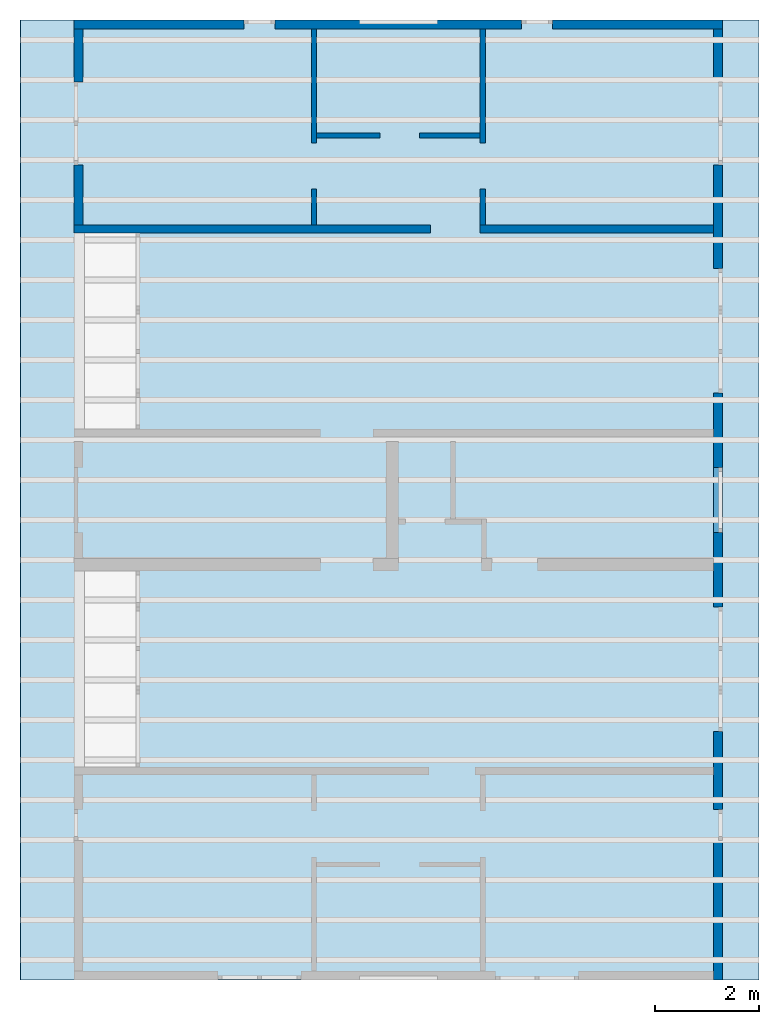
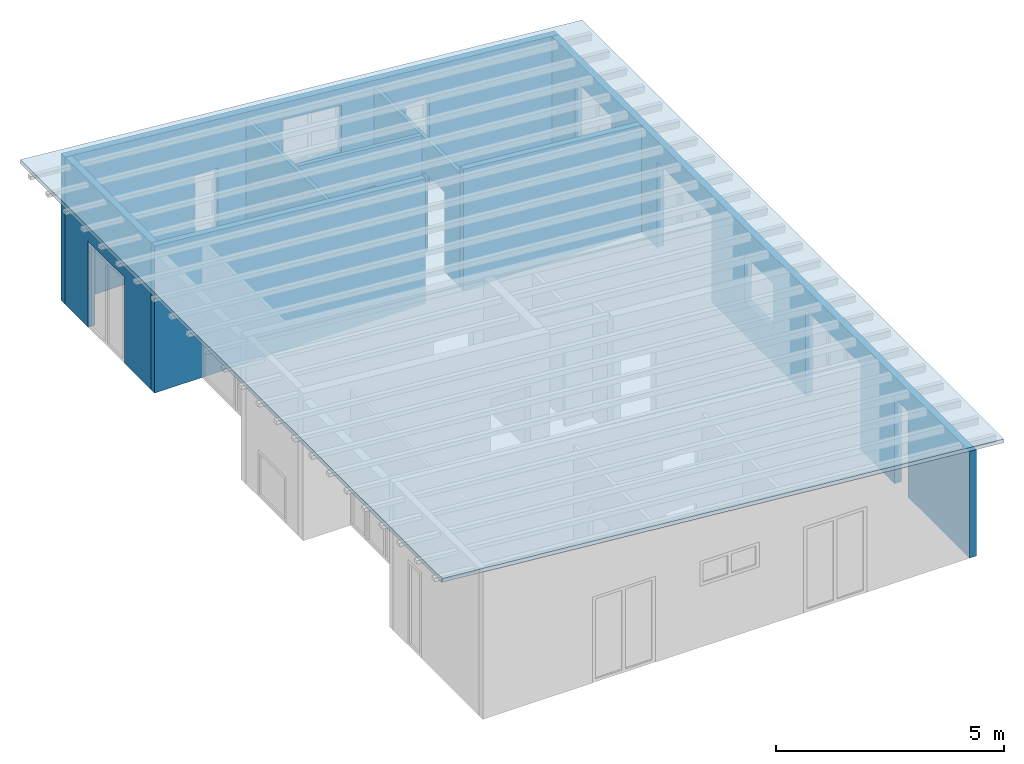
# One storey, part 2 of 13: 8 walls, 1 roof, 14 openings.
"""IFC2X3 building model written with IfcOpenShell, lengths in millimetres."""

from ifc_helpers import new_model, entity, si_unit, converted_unit, frame, frame_2d, origin, origin_with_axes, place, context, project, spatial, polyline, rectangle, outline, extrude, clip, halfspace, faceted_brep, material, layer, layer_set, layer_usage, element, save


model = new_model("IFC2X3")

# Units and contexts
model_context = context("Model", 3, precision=1e-05, world=origin())
plan_context = context("Plan", 3, precision=1e-05, world=origin())
ifc_project = project(units=[si_unit("LENGTHUNIT", "METRE", prefix="MILLI"), converted_unit("PLANEANGLEUNIT", "DEGREE", entity("IfcPlaneAngleMeasure", 0.0174532925199433), si_unit("PLANEANGLEUNIT", "RADIAN"), dimensions=[0, 0, 0, 0, 0, 0, 0]), si_unit("AREAUNIT", "SQUARE_METRE"), si_unit("VOLUMEUNIT", "CUBIC_METRE")], contexts=[model_context, plan_context])

# Building, storey
building_placement = place(None, origin())
building = spatial("IfcBuilding", under=ifc_project, at=building_placement, CompositionType="ELEMENT")
storey_placement = place(building_placement, frame((0.0, 0.0, 4770.0), z_axis=(0.0, 0.0, 1.0), x_axis=(1.0, 0.0, 0.0)))
storey = spatial("IfcBuildingStorey", under=building, at=storey_placement, Name="Geschoss", CompositionType="ELEMENT", Elevation=4770.0)

# Walls
ifc_material_1 = material()
ifc_layer_1 = layer(ifc_material_1, 150.0)
ifc_layer_set_1 = layer_set([ifc_layer_1])
ifc_layer_usage_1 = layer_usage(ifc_layer_set_1, "AXIS2", "POSITIVE", 0.0)
wall_1_placement = place(storey_placement, frame((21188.3517822139, 5708.4375, 0.0), z_axis=(0.0, 0.0, 1.0), x_axis=(1.0, 0.0, 0.0)))
element("IfcWallStandardCase", 1, at=wall_1_placement, inside=storey, material=ifc_layer_usage_1, context=model_context, shape_type="Clipping", body=[
    clip(extrude(rectangle(XDim=6865.03345220687, YDim=150.0, at=frame_2d((3432.51672610344, 75.0), x_axis=(1.0, 0.0))), origin_with_axes(), (0.0, 0.0, 1.0), 3940.60829407405), halfspace(frame((6865.03345220687, 150.0, 3339.99569227971), z_axis=(-0.0871557427476578, 1.12621278238497e-16, -0.996194698091746), x_axis=(1.0, 0.0, 0.0)), True)),
])
ifc_material_2 = material()
ifc_layer_2 = layer(ifc_material_2, 150.0)
ifc_layer_set_2 = layer_set([ifc_layer_2])
ifc_layer_usage_2 = layer_usage(ifc_layer_set_2, "AXIS2", "POSITIVE", 0.0)
wall_2_placement = place(storey_placement, frame((29013.3517822549, 5708.4375, 0.0), z_axis=(0.0, 0.0, 1.0), x_axis=(1.0, 0.0, 0.0)))
element("IfcWallStandardCase", 2, at=wall_2_placement, inside=storey, material=ifc_layer_usage_2, context=model_context, shape_type="Clipping", body=[
    clip(extrude(rectangle(XDim=4499.99999991432, YDim=150.0, at=frame_2d((2249.99999995716, 75.0), x_axis=(1.0, 0.0))), origin_with_axes(), (0.0, 0.0, 1.0), 3256.00950198011), halfspace(frame((0.0, 0.0, 3256.00950198011), z_axis=(-0.0871557427476577, 8.59054269502555e-17, -0.996194698091746), x_axis=(1.0, 0.0, 0.0)), True)),
])

# Wall, opening
ifc_material_3 = material(Name="GD")
ifc_layer_3 = layer(ifc_material_3, 100.0)
ifc_layer_set_3 = layer_set([ifc_layer_3])
ifc_layer_usage_3 = layer_usage(ifc_layer_set_3, "AXIS2", "POSITIVE", 0.0)
wall_3_placement = place(storey_placement, frame((25763.3517822549, 9633.4375, 0.0), z_axis=(0.0, 0.0, 1.0), x_axis=(0.0, -1.0, 0.0)))
wall_3 = element("IfcWallStandardCase", 3, at=wall_3_placement, inside=storey, material=ifc_layer_usage_3, context=model_context, shape_type="Clipping", body=[
    clip(extrude(rectangle(XDim=3775.0, YDim=100.0, at=frame_2d((1887.5, 50.0), x_axis=(1.0, 0.0))), origin_with_axes(), (0.0, 0.0, 1.0), 3340.34765843936), halfspace(frame((0.0, 0.0, 3340.34765843936), z_axis=(0.0, -0.0871557427476622, -0.996194698091745), x_axis=(1.0, 0.0, 0.0)), True)),
])
opening_1_placement = place(wall_3_placement, frame((2199.99999999615, 0.0, 0.0), z_axis=(0.0, 1.0, 0.0), x_axis=(0.0, 0.0, 1.0)))
element("IfcOpeningElement", 4, at=opening_1_placement, cuts=wall_3, ObjectType="Opening", context=model_context, shape_type="SweptSolid", body=[
    extrude(rectangle(XDim=2130.0, YDim=885.000000000514, at=frame_2d((1065.0, 442.500000000257), x_axis=(1.0, 0.0))), origin_with_axes(), (0.0, 0.0, 1.0), 100.0),
])

ifc_material_4 = material(Name="GD")
ifc_layer_4 = layer(ifc_material_4, 99.9999999180436)
ifc_layer_set_4 = layer_set([ifc_layer_4])
ifc_layer_usage_4 = layer_usage(ifc_layer_set_4, "AXIS2", "POSITIVE", 0.0)
wall_4_placement = place(storey_placement, frame((29113.3517821729, 5858.4375, 0.0), z_axis=(0.0, 0.0, 1.0), x_axis=(0.0, 1.0, 0.0)))
wall_4 = element("IfcWallStandardCase", 5, at=wall_4_placement, inside=storey, material=ifc_layer_usage_4, context=model_context, shape_type="Clipping", body=[
    clip(extrude(rectangle(XDim=3775.0, YDim=99.9999999180436, at=frame_2d((1887.5, 49.9999999590218), x_axis=(1.0, 0.0))), origin_with_axes(), (0.0, 0.0, 1.0), 3056.00950198011), halfspace(frame((0.0, 0.0, 3047.26063563469), z_axis=(0.0, 0.0871557427476603, -0.996194698091745), x_axis=(1.0, 0.0, 0.0)), True)),
])
opening_2_placement = place(wall_4_placement, frame((690.000000003335, 0.0, 0.0), z_axis=(0.0, 1.0, 0.0), x_axis=(0.0, 0.0, 1.0)))
element("IfcOpeningElement", 6, at=opening_2_placement, cuts=wall_4, ObjectType="Opening", context=model_context, shape_type="SweptSolid", body=[
    extrude(rectangle(XDim=2130.0, YDim=885.000000000514, at=frame_2d((1065.0, 442.500000000257), x_axis=(1.0, 0.0))), origin_with_axes(), (0.0, 0.0, 1.0), 99.9999999180436),
])

ifc_material_5 = material()
ifc_layer_5 = layer(ifc_material_5, 175.0)
ifc_layer_set_5 = layer_set([ifc_layer_5])
ifc_layer_usage_5 = layer_usage(ifc_layer_set_5, "AXIS2", "POSITIVE", 0.0)
wall_5_placement = place(storey_placement, frame((21188.3517822139, 9633.4375, 0.0), z_axis=(0.0, 0.0, 1.0), x_axis=(0.0, -1.0, 0.0)))
wall_5 = element("IfcWallStandardCase", 7, at=wall_5_placement, inside=storey, material=ifc_layer_usage_5, context=model_context, shape_type="Clipping", body=[
    clip(extrude(rectangle(XDim=3775.0, YDim=175.0, at=frame_2d((1887.5, 87.5), x_axis=(1.0, 0.0))), origin_with_axes(), (0.0, 0.0, 1.0), 3940.60829407405), halfspace(frame((0.0, 175.0, 3925.29777795701), z_axis=(0.0, -0.0871557427476597, -0.996194698091745), x_axis=(1.0, 0.0, 0.0)), True)),
])
opening_3_placement = place(wall_5_placement, frame((1015.0, 0.0, 0.0), z_axis=(0.0, 1.0, 0.0), x_axis=(0.0, 0.0, 1.0)))
element("IfcOpeningElement", 8, at=opening_3_placement, cuts=wall_5, ObjectType="Opening", context=model_context, shape_type="SweptSolid", body=[
    extrude(rectangle(XDim=2300.0, YDim=1600.0, at=frame_2d((1150.0, 800.0), x_axis=(1.0, 0.0))), origin_with_axes(), (0.0, 0.0, 1.0), 175.0),
])

# Wall, openings
ifc_material_6 = material()
ifc_layer_6 = layer(ifc_material_6, 175.0)
ifc_layer_set_6 = layer_set([ifc_layer_6])
ifc_layer_usage_6 = layer_usage(ifc_layer_set_6, "AXIS2", "POSITIVE", 0.0)
wall_6_placement = place(storey_placement, frame((33688.3517822139, 9808.4375, 0.0), z_axis=(0.0, 0.0, 1.0), x_axis=(-1.0, 0.0, 0.0)))
wall_6 = element("IfcWallStandardCase", 9, at=wall_6_placement, inside=storey, material=ifc_layer_usage_6, context=model_context, shape_type="Clipping", body=[
    clip(extrude(rectangle(XDim=12500.0, YDim=175.0, at=frame_2d((6250.0, 87.5), x_axis=(1.0, 0.0))), origin_with_axes(), (0.0, 0.0, 1.0), 3940.60829407405), halfspace(frame((0.0, 175.0, 2847.0), z_axis=(0.0871557427476578, 0.0, -0.996194698091746), x_axis=(1.0, 0.0, 0.0)), True)),
])
opening_4_placement = place(wall_6_placement, frame((5500.00000001148, 0.0, 1635.0), z_axis=(0.0, 1.0, 0.0), x_axis=(0.0, 0.0, 1.0)))
element("IfcOpeningElement", 10, at=opening_4_placement, cuts=wall_6, ObjectType="Opening", context=model_context, shape_type="SweptSolid", body=[
    extrude(outline(polyline([(0.0, 0.0), (1243.18764939358, 0.0), (1374.42064468247, 1500.0), (0.0, 1500.0), (0.0, 0.0)])), origin_with_axes(), (0.0, 0.0, 1.0), 175.0),
])
opening_5_placement = place(wall_6_placement, frame((3274.9999999553, 0.0, 0.0), z_axis=(0.0, 1.0, 0.0), x_axis=(0.0, 0.0, 1.0)))
element("IfcOpeningElement", 11, at=opening_5_placement, cuts=wall_6, ObjectType="Opening", context=model_context, shape_type="SweptSolid", body=[
    extrude(rectangle(XDim=2300.0, YDim=600.0, at=frame_2d((1150.0, 300.0), x_axis=(1.0, 0.0))), origin_with_axes(), (0.0, 0.0, 1.0), 175.0),
])
opening_6_placement = place(wall_6_placement, frame((8625.0000000447, 0.0, 0.0), z_axis=(0.0, 1.0, 0.0), x_axis=(0.0, 0.0, 1.0)))
element("IfcOpeningElement", 12, at=opening_6_placement, cuts=wall_6, ObjectType="Opening", context=model_context, shape_type="SweptSolid", body=[
    extrude(rectangle(XDim=2300.0, YDim=600.0, at=frame_2d((1150.0, 300.0), x_axis=(1.0, 0.0))), origin_with_axes(), (0.0, 0.0, 1.0), 175.0),
])

# Wall, opening
ifc_material_7 = material(Name="GD")
ifc_layer_7 = layer(ifc_material_7, 100.0)
ifc_layer_set_7 = layer_set([ifc_layer_7])
ifc_layer_usage_7 = layer_usage(ifc_layer_set_7, "AXIS2", "POSITIVE", 0.0)
wall_7_placement = place(storey_placement, frame((25863.3517822549, 7533.4375, 0.0), z_axis=(0.0, 0.0, 1.0), x_axis=(1.0, 0.0, 0.0)))
wall_7 = element("IfcWallStandardCase", 13, at=wall_7_placement, inside=storey, material=ifc_layer_usage_7, context=model_context, shape_type="Clipping", body=[
    clip(extrude(rectangle(XDim=3150.0, YDim=100.0, at=frame_2d((1575.0, 50.0), x_axis=(1.0, 0.0))), origin_with_axes(), (0.0, 0.0, 1.0), 3331.59879208677), halfspace(frame((0.0, 0.0, 3331.59879208677), z_axis=(-0.087155742747658, 0.0, -0.996194698091746), x_axis=(1.0, 0.0, 0.0)), True)),
])
opening_7_placement = place(wall_7_placement, frame((1224.98130458333, 0.0, 0.0), z_axis=(0.0, 1.0, 0.0), x_axis=(0.0, 0.0, 1.0)))
element("IfcOpeningElement", 14, at=opening_7_placement, cuts=wall_7, ObjectType="Opening", context=model_context, shape_type="SweptSolid", body=[
    extrude(rectangle(XDim=2130.0, YDim=759.999109685581, at=frame_2d((1065.0, 379.999554842791), x_axis=(1.0, 0.0))), origin_with_axes(), (0.0, 0.0, 1.0), 100.0),
])

# Wall, openings
ifc_material_8 = material()
ifc_layer_8 = layer(ifc_material_8, 175.000000044703)
ifc_layer_set_8 = layer_set([ifc_layer_8])
ifc_layer_usage_8 = layer_usage(ifc_layer_set_8, "AXIS2", "POSITIVE", 0.0)
wall_8_placement = place(storey_placement, frame((33688.3517822139, -8691.5625, 0.0), z_axis=(0.0, 0.0, 1.0), x_axis=(0.0, 1.0, 0.0)))
wall_8 = element("IfcWallStandardCase", 15, at=wall_8_placement, inside=storey, material=ifc_layer_usage_8, context=model_context, shape_type="Clipping", body=[
    clip(extrude(rectangle(XDim=18325.0, YDim=175.000000044703, at=frame_2d((9162.5, 87.5000000223517), x_axis=(1.0, 0.0))), origin_with_axes(), (0.0, 0.0, 1.0), 2862.31051612095), halfspace(frame((18325.0, 175.000000044703, 2862.31051612095), z_axis=(0.0, 0.0871557427476584, -0.996194698091746), x_axis=(1.0, 0.0, 0.0)), True)),
])
opening_8_placement = place(wall_8_placement, frame((8625.0, 1.86264514923096e-09, 875.0), z_axis=(0.0, 1.0, 0.0), x_axis=(0.0, 0.0, 1.0)))
element("IfcOpeningElement", 16, at=opening_8_placement, cuts=wall_8, ObjectType="Opening", context=model_context, shape_type="SweptSolid", body=[
    extrude(rectangle(XDim=1250.0, YDim=1250.0, at=frame_2d((625.0, 625.0), x_axis=(1.0, 0.0))), origin_with_axes(), (0.0, 0.0, 1.0), 175.000000044703),
])
opening_9_placement = place(wall_8_placement, frame((5590.0, 0.0, 0.0), z_axis=(0.0, 1.0, 0.0), x_axis=(0.0, 0.0, 1.0)))
element("IfcOpeningElement", 17, at=opening_9_placement, cuts=wall_8, ObjectType="Opening", context=model_context, shape_type="SweptSolid", body=[
    extrude(rectangle(XDim=2300.0, YDim=1600.0, at=frame_2d((1150.0, 800.0), x_axis=(1.0, 0.0))), origin_with_axes(), (0.0, 0.0, 1.0), 175.000000044703),
])
opening_10_placement = place(wall_8_placement, frame((2690.0, 0.0, 0.0), z_axis=(0.0, 1.0, 0.0), x_axis=(0.0, 0.0, 1.0)))
element("IfcOpeningElement", 18, at=opening_10_placement, cuts=wall_8, ObjectType="Opening", context=model_context, shape_type="SweptSolid", body=[
    extrude(rectangle(XDim=2300.0, YDim=600.0, at=frame_2d((1150.0, 300.0), x_axis=(1.0, 0.0))), origin_with_axes(), (0.0, 0.0, 1.0), 175.000000044703),
])
opening_11_placement = place(wall_8_placement, frame((11310.0, 0.0, 0.0), z_axis=(0.0, 1.0, 0.0), x_axis=(0.0, 0.0, 1.0)))
element("IfcOpeningElement", 19, at=opening_11_placement, cuts=wall_8, ObjectType="Opening", context=model_context, shape_type="SweptSolid", body=[
    extrude(rectangle(XDim=2300.0, YDim=1600.0, at=frame_2d((1150.0, 800.0), x_axis=(1.0, 0.0))), origin_with_axes(), (0.0, 0.0, 1.0), 175.000000044703),
])
opening_12_placement = place(wall_8_placement, frame((15710.0, 0.0, 0.0), z_axis=(0.0, 1.0, 0.0), x_axis=(0.0, 0.0, 1.0)))
element("IfcOpeningElement", 20, at=opening_12_placement, cuts=wall_8, ObjectType="Opening", context=model_context, shape_type="SweptSolid", body=[
    extrude(rectangle(XDim=2300.0, YDim=1600.0, at=frame_2d((1150.0, 800.0), x_axis=(1.0, 0.0))), origin_with_axes(), (0.0, 0.0, 1.0), 175.000000044703),
])
opening_13_placement = place(wall_8_placement, frame((12910.0, 0.0, 0.0), z_axis=(0.0, 1.0, 0.0), x_axis=(0.0, 0.0, 1.0)))
element("IfcOpeningElement", 21, at=opening_13_placement, cuts=wall_8, ObjectType="Opening", context=model_context, shape_type="SweptSolid", body=[
    extrude(rectangle(XDim=2300.0, YDim=800.0, at=frame_2d((1150.0, 400.0), x_axis=(1.0, 0.0))), origin_with_axes(), (0.0, 0.0, 1.0), 175.000000044703),
])
opening_14_placement = place(wall_8_placement, frame((4790.0, 0.0, 0.0), z_axis=(0.0, 1.0, 0.0), x_axis=(0.0, 0.0, 1.0)))
element("IfcOpeningElement", 22, at=opening_14_placement, cuts=wall_8, ObjectType="Opening", context=model_context, shape_type="SweptSolid", body=[
    extrude(rectangle(XDim=2300.0, YDim=800.0, at=frame_2d((1150.0, 400.0), x_axis=(1.0, 0.0))), origin_with_axes(), (0.0, 0.0, 1.0), 175.000000044703),
])

# Roof
ifc_material_9 = material()
roof_placement = place(None, origin())
element("IfcRoof", 23, at=roof_placement, inside=storey, material=ifc_material_9, ShapeType="NOTDEFINED", context=model_context, shape_type="Brep", body=[
    faceted_brep([(34376.9724966034, 9808.4375, 7556.7534940218), (20147.0020158289, 9808.4375, 8801.7145933981), (20147.0020158289, -8691.5625, 8801.7145933981), (34376.9724966034, -8691.5625, 7556.7534940218), (34385.6880708781, 9808.4375, 7656.37296383097), (34385.6880708781, -8691.5625, 7656.37296383097), (20155.7175901036, -8691.5625, 8901.33406320728), (20155.7175901036, 9808.4375, 8901.33406320728), (20155.7175901036, 9808.4375, 8901.33406320728), (20155.7175901036, -8691.5625, 8901.33406320728), (20147.0020158289, -8691.5625, 8801.7145933981), (20147.0020158289, 9808.4375, 8801.7145933981), (20155.7175901036, -8691.5625, 8901.33406320728), (34385.6880708781, -8691.5625, 7656.37296383097), (34385.6880708781, -8691.5625, 7556.7534940218), (34376.9724966034, -8691.5625, 7556.7534940218), (20147.0020158289, -8691.5625, 8801.7145933981), (34385.6880708781, 9808.4375, 7656.37296383097), (20155.7175901036, 9808.4375, 8901.33406320728), (20147.0020158289, 9808.4375, 8801.7145933981), (34376.9724966034, 9808.4375, 7556.7534940218), (34385.6880708781, 9808.4375, 7556.7534940218), (34385.6880708781, -8691.5625, 7556.7534940218), (34385.6880708781, 9808.4375, 7556.7534940218), (34376.9724966034, 9808.4375, 7556.7534940218), (34376.9724966034, -8691.5625, 7556.7534940218), (34385.6880708781, -8691.5625, 7656.37296383097), (34385.6880708781, 9808.4375, 7656.37296383097), (34385.6880708781, 9808.4375, 7556.7534940218), (34385.6880708781, -8691.5625, 7556.7534940218)], [[[0, 1, 2, 3]], [[4, 5, 6, 7]], [[8, 9, 10, 11]], [[12, 13, 14, 15, 16]], [[17, 18, 19, 20, 21]], [[22, 23, 24, 25]], [[26, 27, 28, 29]]], orient=[[False], [False], [False], [False], [False], [False], [False]]),
])

save(model, "model.ifc")
